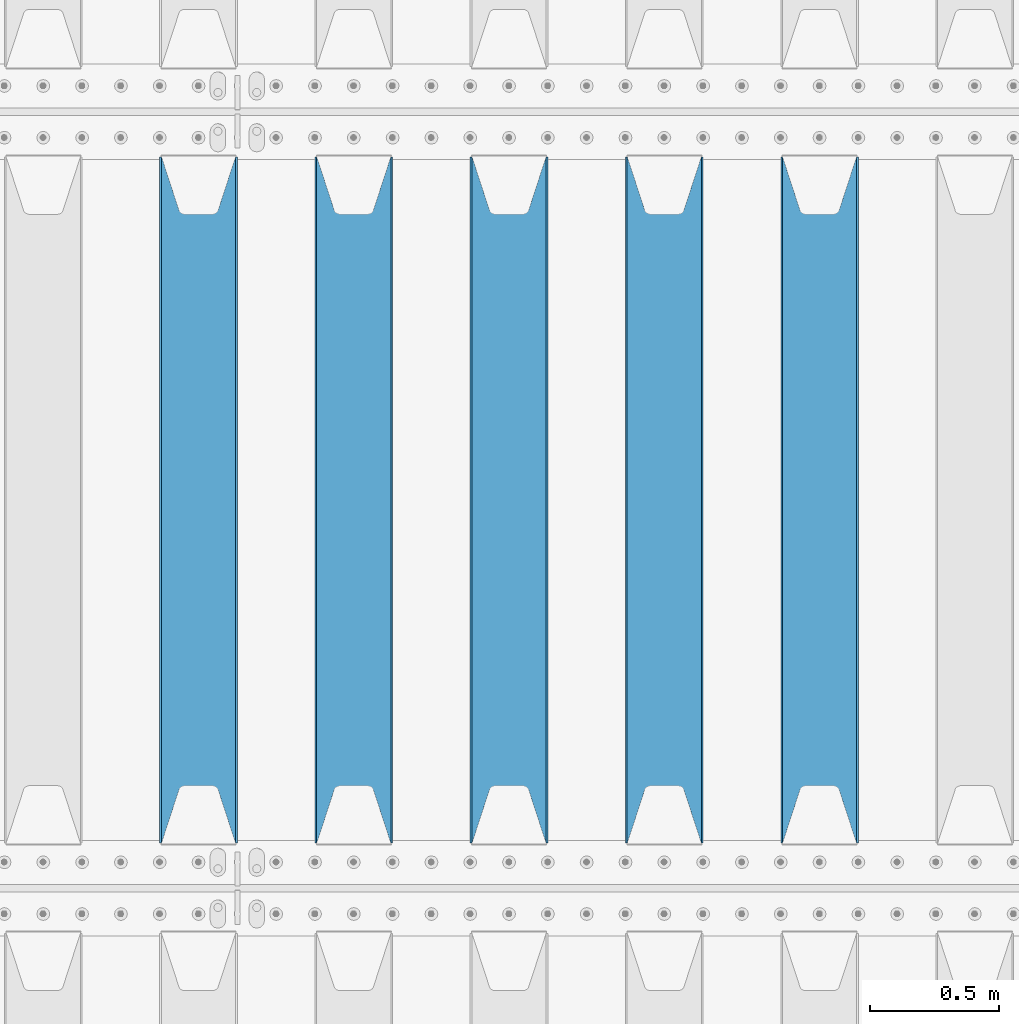
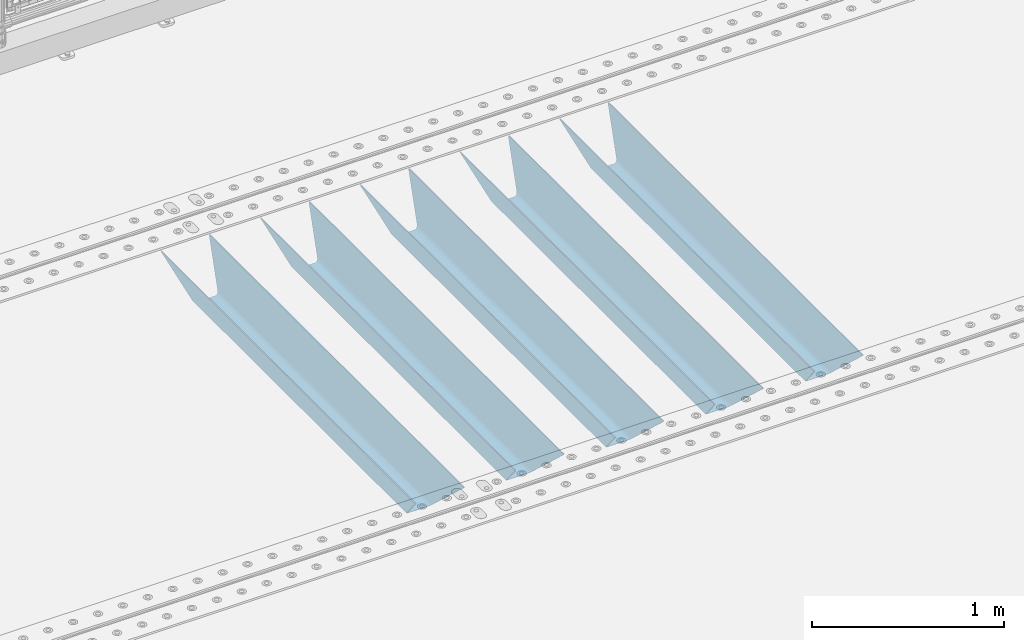
# One storey, part 115 of 240: 5 beams.
"""IFC2X3 building model written with IfcOpenShell, lengths in millimetres."""

from ifc_helpers import new_model, si_unit, frame, origin_with_axes, place, context, subcontext, project, spatial, faceted_brep, material, type_object, element, save


model = new_model("IFC2X3")

# Units and contexts
model_context = context("Model", 3, precision=1e-05, world=origin_with_axes())
body_context = subcontext(model_context, "Body", "Model", "MODEL_VIEW")
ifc_project = project(units=[si_unit("LENGTHUNIT", "METRE", prefix="MILLI"), si_unit("AREAUNIT", "SQUARE_METRE"), si_unit("VOLUMEUNIT", "CUBIC_METRE"), si_unit("MASSUNIT", "GRAM", prefix="KILO"), si_unit("TIMEUNIT", "SECOND"), si_unit("PLANEANGLEUNIT", "RADIAN"), si_unit("SOLIDANGLEUNIT", "STERADIAN"), si_unit("THERMODYNAMICTEMPERATUREUNIT", "DEGREE_CELSIUS"), si_unit("LUMINOUSINTENSITYUNIT", "LUMEN")], contexts=[model_context])

# Site, building, storey
site_placement = place(None, origin_with_axes())
site = spatial("IfcSite", under=ifc_project, at=site_placement, CompositionType="ELEMENT")
building_placement = place(site_placement, origin_with_axes())
building = spatial("IfcBuilding", under=site, at=building_placement, Name="Standard", CompositionType="ELEMENT")
storey_placement = place(building_placement, origin_with_axes())
storey = spatial("IfcBuildingStorey", under=building, at=storey_placement, Name="Undefined", CompositionType="ELEMENT", Elevation=0.0)

# Beams
ifc_material = material(Name="STEEL/S355N")
beam_type = type_object("IfcBeamType", PredefinedType="NOTDEFINED")
beam_1_placement = place(storey_placement, frame((48850.0, 30175.0, -115.0), z_axis=(0.0, 0.0, 1.0), x_axis=(0.0, 1.0, 0.0)))
element("IfcBeam", 1, at=beam_1_placement, inside=storey, type_object=beam_type, material=ifc_material, context=body_context, shape_type="Brep", body=[
    faceted_brep([(0.0, 150.0, 115.0), (0.0, 143.690000000002, 115.0), (2650.00000000297, 143.690000000002, 115.0), (2650.00000000297, 150.0, 115.0), (2650.00000000297, 142.059565218406, 110.000000003094), (2650.00000000297, 148.369565218403, 110.000000003094), (2441.90079219209, -80.1103600731149, -98.0992078077845), (2437.7588105432, -77.5672621345584, -102.241189456673), (2434.06523489747, -74.4080125315522, -105.934765102404), (2430.9108609509, -70.7102721255724, -109.089139048974), (2428.37322971128, -66.5649389910031, -111.626770288588), (2426.51472138055, -62.0739139532889, -113.485278619323), (2425.38102192092, -57.3475956567636, -114.618978078955), (2424.99999999987, -52.5021667386536, -115.0), (2424.99999999987, 52.5021667386536, -115.0), (2425.38102192092, 57.3475956567636, -114.618978078955), (2426.51472138055, 62.0739139532889, -113.485278619323), (2428.37322971128, 66.5649389910031, -111.626770288588), (2430.9108609509, 70.7102721255724, -109.089139048974), (2434.06523489747, 74.4080125315522, -105.934765102404), (2437.7588105432, 77.5672621345584, -102.241189456673), (2441.90079219209, 80.1103600731149, -98.0992078077846), (2446.38936140512, 81.9747917625791, -93.6106385947584), (2448.2494850041, 76.2713538057287, -91.7505149957729), (2444.62967112263, 74.76777986261, -95.3703288772456), (2441.28936334127, 72.7168944282894, -98.710636658607), (2438.31067330439, 70.1691124903809, -101.689326695487), (2435.76682334748, 67.1870637758839, -104.233176652398), (2433.72034654134, 63.8440531834931, -106.279653458539), (2432.22154950042, 60.2222587982324, -107.778450499454), (2431.30727574265, 56.4107117849126, -108.692724257221), (2430.99999999987, 52.5031078186876, -109.0), (2430.99999999987, -52.5031078186876, -109.0), (2431.30727574265, -56.4107117849126, -108.692724257221), (2432.22154950042, -60.2222587982324, -107.778450499454), (2433.72034654134, -63.8440531834931, -106.279653458539), (2435.76682334748, -67.1870637758839, -104.233176652398), (2438.31067330439, -70.1691124903809, -101.689326695487), (2441.28936334127, -72.7168944282894, -98.7106366586071), (2444.62967112263, -74.76777986261, -95.3703288772457), (2448.2494850041, -76.2713538057287, -91.7505149957729), (2650.00000000297, -142.059565218406, 110.000000003094), (2650.00000000297, -148.369565218403, 110.000000003094), (2446.38936140512, -81.9747917625791, -93.6106385947584), (2650.00000000297, -143.690000000002, 115.0), (2650.00000000297, -150.0, 115.0), (0.0, -143.690000000002, 115.0), (0.0, -150.0, 115.0), (0.0, -148.369565218258, 110.000000002667), (203.610638597427, -81.9747917625791, -93.6106385947584), (208.09920781045, -80.1103600731149, -98.0992078077845), (212.241189459342, -77.5672621345584, -102.241189456673), (215.93476510507, -74.4080125315522, -105.934765102404), (219.089139051641, -70.7102721255724, -109.089139048974), (221.626770291256, -66.5649389910031, -111.626770288588), (223.485278621989, -62.0739139532889, -113.485278619323), (224.618978081624, -57.3475956567636, -114.618978078955), (225.000000002663, -52.5021667386536, -115.0), (225.000000002663, 52.5021667386536, -115.0), (224.618978081624, 57.3475956567636, -114.618978078955), (223.485278621989, 62.0739139532889, -113.485278619323), (221.626770291256, 66.5649389910031, -111.626770288588), (219.089139051641, 70.7102721255724, -109.089139048974), (215.93476510507, 74.4080125315522, -105.934765102404), (212.241189459342, 77.5672621345584, -102.241189456673), (208.09920781045, 80.1103600731149, -98.0992078077846), (203.610638597427, 81.9747917625791, -93.6106385947584), (0.0, 148.369565218258, 110.000000002667), (0.0, 142.05956521826, 110.000000002667), (201.750514998439, 76.2713538057287, -91.7505149957729), (205.370328879908, 74.76777986261, -95.3703288772456), (208.710636661275, 72.7168944282894, -98.710636658607), (211.689326698153, 70.1691124903809, -101.689326695487), (214.233176655063, 67.1870637758839, -104.233176652398), (216.279653461206, 63.8440531834931, -106.279653458539), (217.778450502123, 60.2222587982324, -107.778450499454), (218.692724259887, 56.4107117849126, -108.692724257221), (219.000000002667, 52.5031078186876, -109.0), (219.000000002667, -52.5031078186876, -109.0), (218.692724259887, -56.4107117849126, -108.692724257221), (217.778450502123, -60.2222587982324, -107.778450499454), (216.279653461206, -63.8440531834931, -106.279653458539), (214.233176655063, -67.1870637758839, -104.233176652398), (211.689326698153, -70.1691124903809, -101.689326695487), (208.710636661275, -72.7168944282894, -98.7106366586071), (205.370328879915, -74.76777986261, -95.3703288772457), (201.750514998439, -76.2713538057287, -91.7505149957729), (0.0, -142.05956521826, 110.000000002667)], [[[0, 1, 2, 3]], [[3, 2, 4, 5]], [[6, 7, 8, 9, 10, 11, 12, 13, 14, 15, 16, 17, 18, 19, 20, 21, 22, 5, 4, 23, 24, 25, 26, 27, 28, 29, 30, 31, 32, 33, 34, 35, 36, 37, 38, 39, 40, 41, 42, 43]], [[44, 45, 42, 41]], [[46, 47, 45, 44]], [[43, 42, 45, 47, 48, 49]], [[6, 43, 49, 50]], [[7, 6, 50, 51]], [[8, 7, 51, 52]], [[9, 8, 52, 53]], [[10, 9, 53, 54]], [[11, 10, 54, 55]], [[12, 11, 55, 56]], [[13, 12, 56, 57]], [[14, 13, 57, 58]], [[15, 14, 58, 59]], [[16, 15, 59, 60]], [[17, 16, 60, 61]], [[18, 17, 61, 62]], [[19, 18, 62, 63]], [[20, 19, 63, 64]], [[21, 20, 64, 65]], [[22, 21, 65, 66]], [[0, 3, 5, 22, 66, 67]], [[1, 0, 67, 68]], [[23, 4, 2, 1, 68, 69]], [[24, 23, 69, 70]], [[25, 24, 70, 71]], [[26, 25, 71, 72]], [[27, 26, 72, 73]], [[28, 27, 73, 74]], [[29, 28, 74, 75]], [[30, 29, 75, 76]], [[31, 30, 76, 77]], [[32, 31, 77, 78]], [[33, 32, 78, 79]], [[34, 33, 79, 80]], [[35, 34, 80, 81]], [[36, 35, 81, 82]], [[37, 36, 82, 83]], [[38, 37, 83, 84]], [[39, 38, 84, 85]], [[40, 39, 85, 86]], [[46, 44, 41, 40, 86, 87]], [[47, 46, 87, 48]], [[86, 85, 84, 83, 82, 81, 80, 79, 78, 77, 76, 75, 74, 73, 72, 71, 70, 69, 68, 67, 66, 65, 64, 63, 62, 61, 60, 59, 58, 57, 56, 55, 54, 53, 52, 51, 50, 49, 48, 87]]]),
])
beam_2_placement = place(storey_placement, frame((48250.0, 30175.0, -115.0), z_axis=(0.0, 0.0, 1.0), x_axis=(0.0, 1.0, 0.0)))
element("IfcBeam", 2, at=beam_2_placement, inside=storey, type_object=beam_type, material=ifc_material, context=body_context, shape_type="Brep", body=[
    faceted_brep([(0.0, 150.0, 115.0), (0.0, 143.690000000002, 115.0), (2650.00000000297, 143.690000000002, 115.0), (2650.00000000297, 150.0, 115.0), (2650.00000000297, 142.059565218406, 110.000000003094), (2650.00000000297, 148.369565218403, 110.000000003094), (2441.90079219209, -80.1103600731149, -98.0992078077845), (2437.7588105432, -77.5672621345584, -102.241189456673), (2434.06523489747, -74.4080125315522, -105.934765102404), (2430.9108609509, -70.7102721255724, -109.089139048974), (2428.37322971128, -66.5649389910031, -111.626770288588), (2426.51472138055, -62.0739139532889, -113.485278619323), (2425.38102192092, -57.3475956567636, -114.618978078955), (2424.99999999987, -52.5021667386536, -115.0), (2424.99999999987, 52.5021667386536, -115.0), (2425.38102192092, 57.3475956567636, -114.618978078955), (2426.51472138055, 62.0739139532889, -113.485278619323), (2428.37322971128, 66.5649389910031, -111.626770288588), (2430.9108609509, 70.7102721255724, -109.089139048974), (2434.06523489747, 74.4080125315522, -105.934765102404), (2437.7588105432, 77.5672621345584, -102.241189456673), (2441.90079219209, 80.1103600731149, -98.0992078077846), (2446.38936140512, 81.9747917625791, -93.6106385947584), (2448.2494850041, 76.2713538057287, -91.7505149957729), (2444.62967112263, 74.76777986261, -95.3703288772456), (2441.28936334127, 72.7168944282894, -98.710636658607), (2438.31067330439, 70.1691124903809, -101.689326695487), (2435.76682334748, 67.1870637758839, -104.233176652398), (2433.72034654134, 63.8440531834931, -106.279653458539), (2432.22154950042, 60.2222587982324, -107.778450499454), (2431.30727574265, 56.4107117849126, -108.692724257221), (2430.99999999987, 52.5031078186876, -109.0), (2430.99999999987, -52.5031078186876, -109.0), (2431.30727574265, -56.4107117849126, -108.692724257221), (2432.22154950042, -60.2222587982324, -107.778450499454), (2433.72034654134, -63.8440531834931, -106.279653458539), (2435.76682334748, -67.1870637758839, -104.233176652398), (2438.31067330439, -70.1691124903809, -101.689326695487), (2441.28936334127, -72.7168944282894, -98.7106366586071), (2444.62967112263, -74.76777986261, -95.3703288772457), (2448.2494850041, -76.2713538057287, -91.7505149957729), (2650.00000000297, -142.059565218406, 110.000000003094), (2650.00000000297, -148.369565218403, 110.000000003094), (2446.38936140512, -81.9747917625791, -93.6106385947584), (2650.00000000297, -143.690000000002, 115.0), (2650.00000000297, -150.0, 115.0), (0.0, -143.690000000002, 115.0), (0.0, -150.0, 115.0), (0.0, -148.369565218258, 110.000000002667), (203.610638597427, -81.9747917625791, -93.6106385947584), (208.09920781045, -80.1103600731149, -98.0992078077845), (212.241189459342, -77.5672621345584, -102.241189456673), (215.93476510507, -74.4080125315522, -105.934765102404), (219.089139051641, -70.7102721255724, -109.089139048974), (221.626770291256, -66.5649389910031, -111.626770288588), (223.485278621989, -62.0739139532889, -113.485278619323), (224.618978081624, -57.3475956567636, -114.618978078955), (225.000000002663, -52.5021667386536, -115.0), (225.000000002663, 52.5021667386536, -115.0), (224.618978081624, 57.3475956567636, -114.618978078955), (223.485278621989, 62.0739139532889, -113.485278619323), (221.626770291256, 66.5649389910031, -111.626770288588), (219.089139051641, 70.7102721255724, -109.089139048974), (215.93476510507, 74.4080125315522, -105.934765102404), (212.241189459342, 77.5672621345584, -102.241189456673), (208.09920781045, 80.1103600731149, -98.0992078077846), (203.610638597427, 81.9747917625791, -93.6106385947584), (0.0, 148.369565218258, 110.000000002667), (0.0, 142.05956521826, 110.000000002667), (201.750514998439, 76.2713538057287, -91.7505149957729), (205.370328879908, 74.76777986261, -95.3703288772456), (208.710636661275, 72.7168944282894, -98.710636658607), (211.689326698153, 70.1691124903809, -101.689326695487), (214.233176655063, 67.1870637758839, -104.233176652398), (216.279653461206, 63.8440531834931, -106.279653458539), (217.778450502123, 60.2222587982324, -107.778450499454), (218.692724259887, 56.4107117849126, -108.692724257221), (219.000000002667, 52.5031078186876, -109.0), (219.000000002667, -52.5031078186876, -109.0), (218.692724259887, -56.4107117849126, -108.692724257221), (217.778450502123, -60.2222587982324, -107.778450499454), (216.279653461206, -63.8440531834931, -106.279653458539), (214.233176655063, -67.1870637758839, -104.233176652398), (211.689326698153, -70.1691124903809, -101.689326695487), (208.710636661275, -72.7168944282894, -98.7106366586071), (205.370328879915, -74.76777986261, -95.3703288772457), (201.750514998439, -76.2713538057287, -91.7505149957729), (0.0, -142.05956521826, 110.000000002667)], [[[0, 1, 2, 3]], [[3, 2, 4, 5]], [[6, 7, 8, 9, 10, 11, 12, 13, 14, 15, 16, 17, 18, 19, 20, 21, 22, 5, 4, 23, 24, 25, 26, 27, 28, 29, 30, 31, 32, 33, 34, 35, 36, 37, 38, 39, 40, 41, 42, 43]], [[44, 45, 42, 41]], [[46, 47, 45, 44]], [[43, 42, 45, 47, 48, 49]], [[6, 43, 49, 50]], [[7, 6, 50, 51]], [[8, 7, 51, 52]], [[9, 8, 52, 53]], [[10, 9, 53, 54]], [[11, 10, 54, 55]], [[12, 11, 55, 56]], [[13, 12, 56, 57]], [[14, 13, 57, 58]], [[15, 14, 58, 59]], [[16, 15, 59, 60]], [[17, 16, 60, 61]], [[18, 17, 61, 62]], [[19, 18, 62, 63]], [[20, 19, 63, 64]], [[21, 20, 64, 65]], [[22, 21, 65, 66]], [[0, 3, 5, 22, 66, 67]], [[1, 0, 67, 68]], [[23, 4, 2, 1, 68, 69]], [[24, 23, 69, 70]], [[25, 24, 70, 71]], [[26, 25, 71, 72]], [[27, 26, 72, 73]], [[28, 27, 73, 74]], [[29, 28, 74, 75]], [[30, 29, 75, 76]], [[31, 30, 76, 77]], [[32, 31, 77, 78]], [[33, 32, 78, 79]], [[34, 33, 79, 80]], [[35, 34, 80, 81]], [[36, 35, 81, 82]], [[37, 36, 82, 83]], [[38, 37, 83, 84]], [[39, 38, 84, 85]], [[40, 39, 85, 86]], [[46, 44, 41, 40, 86, 87]], [[47, 46, 87, 48]], [[86, 85, 84, 83, 82, 81, 80, 79, 78, 77, 76, 75, 74, 73, 72, 71, 70, 69, 68, 67, 66, 65, 64, 63, 62, 61, 60, 59, 58, 57, 56, 55, 54, 53, 52, 51, 50, 49, 48, 87]]]),
])
beam_3_placement = place(storey_placement, frame((47650.0, 30175.0, -115.0), z_axis=(0.0, 0.0, 1.0), x_axis=(0.0, 1.0, 0.0)))
element("IfcBeam", 3, at=beam_3_placement, inside=storey, type_object=beam_type, material=ifc_material, context=body_context, shape_type="Brep", body=[
    faceted_brep([(0.0, 150.0, 115.0), (0.0, 143.690000000002, 115.0), (2650.00000000297, 143.690000000002, 115.0), (2650.00000000297, 150.0, 115.0), (2650.00000000297, 142.059565218406, 110.000000003094), (2650.00000000297, 148.369565218403, 110.000000003094), (2441.90079219209, -80.1103600731149, -98.0992078077845), (2437.7588105432, -77.5672621345584, -102.241189456673), (2434.06523489747, -74.4080125315522, -105.934765102404), (2430.9108609509, -70.7102721255724, -109.089139048974), (2428.37322971128, -66.5649389910031, -111.626770288588), (2426.51472138055, -62.0739139532889, -113.485278619323), (2425.38102192092, -57.3475956567636, -114.618978078955), (2424.99999999987, -52.5021667386536, -115.0), (2424.99999999987, 52.5021667386536, -115.0), (2425.38102192092, 57.3475956567636, -114.618978078955), (2426.51472138055, 62.0739139532889, -113.485278619323), (2428.37322971128, 66.5649389910031, -111.626770288588), (2430.9108609509, 70.7102721255724, -109.089139048974), (2434.06523489747, 74.4080125315522, -105.934765102404), (2437.7588105432, 77.5672621345584, -102.241189456673), (2441.90079219209, 80.1103600731149, -98.0992078077846), (2446.38936140512, 81.9747917625791, -93.6106385947584), (2448.2494850041, 76.2713538057287, -91.7505149957729), (2444.62967112263, 74.76777986261, -95.3703288772456), (2441.28936334127, 72.7168944282894, -98.710636658607), (2438.31067330439, 70.1691124903809, -101.689326695487), (2435.76682334748, 67.1870637758839, -104.233176652398), (2433.72034654134, 63.8440531834931, -106.279653458539), (2432.22154950042, 60.2222587982324, -107.778450499454), (2431.30727574265, 56.4107117849126, -108.692724257221), (2430.99999999987, 52.5031078186876, -109.0), (2430.99999999987, -52.5031078186876, -109.0), (2431.30727574265, -56.4107117849126, -108.692724257221), (2432.22154950042, -60.2222587982324, -107.778450499454), (2433.72034654134, -63.8440531834931, -106.279653458539), (2435.76682334748, -67.1870637758839, -104.233176652398), (2438.31067330439, -70.1691124903809, -101.689326695487), (2441.28936334127, -72.7168944282894, -98.7106366586071), (2444.62967112263, -74.76777986261, -95.3703288772457), (2448.2494850041, -76.2713538057287, -91.7505149957729), (2650.00000000297, -142.059565218406, 110.000000003094), (2650.00000000297, -148.369565218403, 110.000000003094), (2446.38936140512, -81.9747917625791, -93.6106385947584), (2650.00000000297, -143.690000000002, 115.0), (2650.00000000297, -150.0, 115.0), (0.0, -143.690000000002, 115.0), (0.0, -150.0, 115.0), (0.0, -148.369565218258, 110.000000002667), (203.610638597427, -81.9747917625791, -93.6106385947584), (208.09920781045, -80.1103600731149, -98.0992078077845), (212.241189459342, -77.5672621345584, -102.241189456673), (215.93476510507, -74.4080125315522, -105.934765102404), (219.089139051641, -70.7102721255724, -109.089139048974), (221.626770291256, -66.5649389910031, -111.626770288588), (223.485278621989, -62.0739139532889, -113.485278619323), (224.618978081624, -57.3475956567636, -114.618978078955), (225.000000002663, -52.5021667386536, -115.0), (225.000000002663, 52.5021667386536, -115.0), (224.618978081624, 57.3475956567636, -114.618978078955), (223.485278621989, 62.0739139532889, -113.485278619323), (221.626770291256, 66.5649389910031, -111.626770288588), (219.089139051641, 70.7102721255724, -109.089139048974), (215.93476510507, 74.4080125315522, -105.934765102404), (212.241189459342, 77.5672621345584, -102.241189456673), (208.09920781045, 80.1103600731149, -98.0992078077846), (203.610638597427, 81.9747917625791, -93.6106385947584), (0.0, 148.369565218258, 110.000000002667), (0.0, 142.05956521826, 110.000000002667), (201.750514998439, 76.2713538057287, -91.7505149957729), (205.370328879908, 74.76777986261, -95.3703288772456), (208.710636661275, 72.7168944282894, -98.710636658607), (211.689326698153, 70.1691124903809, -101.689326695487), (214.233176655063, 67.1870637758839, -104.233176652398), (216.279653461206, 63.8440531834931, -106.279653458539), (217.778450502123, 60.2222587982324, -107.778450499454), (218.692724259887, 56.4107117849126, -108.692724257221), (219.000000002667, 52.5031078186876, -109.0), (219.000000002667, -52.5031078186876, -109.0), (218.692724259887, -56.4107117849126, -108.692724257221), (217.778450502123, -60.2222587982324, -107.778450499454), (216.279653461206, -63.8440531834931, -106.279653458539), (214.233176655063, -67.1870637758839, -104.233176652398), (211.689326698153, -70.1691124903809, -101.689326695487), (208.710636661275, -72.7168944282894, -98.7106366586071), (205.370328879915, -74.76777986261, -95.3703288772457), (201.750514998439, -76.2713538057287, -91.7505149957729), (0.0, -142.05956521826, 110.000000002667)], [[[0, 1, 2, 3]], [[3, 2, 4, 5]], [[6, 7, 8, 9, 10, 11, 12, 13, 14, 15, 16, 17, 18, 19, 20, 21, 22, 5, 4, 23, 24, 25, 26, 27, 28, 29, 30, 31, 32, 33, 34, 35, 36, 37, 38, 39, 40, 41, 42, 43]], [[44, 45, 42, 41]], [[46, 47, 45, 44]], [[43, 42, 45, 47, 48, 49]], [[6, 43, 49, 50]], [[7, 6, 50, 51]], [[8, 7, 51, 52]], [[9, 8, 52, 53]], [[10, 9, 53, 54]], [[11, 10, 54, 55]], [[12, 11, 55, 56]], [[13, 12, 56, 57]], [[14, 13, 57, 58]], [[15, 14, 58, 59]], [[16, 15, 59, 60]], [[17, 16, 60, 61]], [[18, 17, 61, 62]], [[19, 18, 62, 63]], [[20, 19, 63, 64]], [[21, 20, 64, 65]], [[22, 21, 65, 66]], [[0, 3, 5, 22, 66, 67]], [[1, 0, 67, 68]], [[23, 4, 2, 1, 68, 69]], [[24, 23, 69, 70]], [[25, 24, 70, 71]], [[26, 25, 71, 72]], [[27, 26, 72, 73]], [[28, 27, 73, 74]], [[29, 28, 74, 75]], [[30, 29, 75, 76]], [[31, 30, 76, 77]], [[32, 31, 77, 78]], [[33, 32, 78, 79]], [[34, 33, 79, 80]], [[35, 34, 80, 81]], [[36, 35, 81, 82]], [[37, 36, 82, 83]], [[38, 37, 83, 84]], [[39, 38, 84, 85]], [[40, 39, 85, 86]], [[46, 44, 41, 40, 86, 87]], [[47, 46, 87, 48]], [[86, 85, 84, 83, 82, 81, 80, 79, 78, 77, 76, 75, 74, 73, 72, 71, 70, 69, 68, 67, 66, 65, 64, 63, 62, 61, 60, 59, 58, 57, 56, 55, 54, 53, 52, 51, 50, 49, 48, 87]]]),
])
beam_4_placement = place(storey_placement, frame((47050.0, 30175.0, -115.0), z_axis=(0.0, 0.0, 1.0), x_axis=(0.0, 1.0, 0.0)))
element("IfcBeam", 4, at=beam_4_placement, inside=storey, type_object=beam_type, material=ifc_material, context=body_context, shape_type="Brep", body=[
    faceted_brep([(0.0, 150.0, 115.0), (0.0, 143.690000000002, 115.0), (2650.00000000297, 143.690000000002, 115.0), (2650.00000000297, 150.0, 115.0), (2650.00000000297, 142.059565218406, 110.000000003094), (2650.00000000297, 148.369565218403, 110.000000003094), (2441.90079219209, -80.1103600731149, -98.0992078077845), (2437.7588105432, -77.5672621345584, -102.241189456673), (2434.06523489747, -74.4080125315522, -105.934765102404), (2430.9108609509, -70.7102721255724, -109.089139048974), (2428.37322971128, -66.5649389910031, -111.626770288588), (2426.51472138055, -62.0739139532889, -113.485278619323), (2425.38102192092, -57.3475956567636, -114.618978078955), (2424.99999999987, -52.5021667386536, -115.0), (2424.99999999987, 52.5021667386536, -115.0), (2425.38102192092, 57.3475956567636, -114.618978078955), (2426.51472138055, 62.0739139532889, -113.485278619323), (2428.37322971128, 66.5649389910031, -111.626770288588), (2430.9108609509, 70.7102721255724, -109.089139048974), (2434.06523489747, 74.4080125315522, -105.934765102404), (2437.7588105432, 77.5672621345584, -102.241189456673), (2441.90079219209, 80.1103600731149, -98.0992078077846), (2446.38936140512, 81.9747917625791, -93.6106385947584), (2448.2494850041, 76.2713538057287, -91.7505149957729), (2444.62967112263, 74.76777986261, -95.3703288772456), (2441.28936334127, 72.7168944282894, -98.710636658607), (2438.31067330439, 70.1691124903809, -101.689326695487), (2435.76682334748, 67.1870637758839, -104.233176652398), (2433.72034654134, 63.8440531834931, -106.279653458539), (2432.22154950042, 60.2222587982324, -107.778450499454), (2431.30727574265, 56.4107117849126, -108.692724257221), (2430.99999999987, 52.5031078186876, -109.0), (2430.99999999987, -52.5031078186876, -109.0), (2431.30727574265, -56.4107117849126, -108.692724257221), (2432.22154950042, -60.2222587982324, -107.778450499454), (2433.72034654134, -63.8440531834931, -106.279653458539), (2435.76682334748, -67.1870637758839, -104.233176652398), (2438.31067330439, -70.1691124903809, -101.689326695487), (2441.28936334127, -72.7168944282894, -98.7106366586071), (2444.62967112263, -74.76777986261, -95.3703288772457), (2448.2494850041, -76.2713538057287, -91.7505149957729), (2650.00000000297, -142.059565218406, 110.000000003094), (2650.00000000297, -148.369565218403, 110.000000003094), (2446.38936140512, -81.9747917625791, -93.6106385947584), (2650.00000000297, -143.690000000002, 115.0), (2650.00000000297, -150.0, 115.0), (0.0, -143.690000000002, 115.0), (0.0, -150.0, 115.0), (0.0, -148.369565218258, 110.000000002667), (203.610638597427, -81.9747917625791, -93.6106385947584), (208.09920781045, -80.1103600731149, -98.0992078077845), (212.241189459342, -77.5672621345584, -102.241189456673), (215.93476510507, -74.4080125315522, -105.934765102404), (219.089139051641, -70.7102721255724, -109.089139048974), (221.626770291256, -66.5649389910031, -111.626770288588), (223.485278621989, -62.0739139532889, -113.485278619323), (224.618978081624, -57.3475956567636, -114.618978078955), (225.000000002663, -52.5021667386536, -115.0), (225.000000002663, 52.5021667386536, -115.0), (224.618978081624, 57.3475956567636, -114.618978078955), (223.485278621989, 62.0739139532889, -113.485278619323), (221.626770291256, 66.5649389910031, -111.626770288588), (219.089139051641, 70.7102721255724, -109.089139048974), (215.93476510507, 74.4080125315522, -105.934765102404), (212.241189459342, 77.5672621345584, -102.241189456673), (208.09920781045, 80.1103600731149, -98.0992078077846), (203.610638597427, 81.9747917625791, -93.6106385947584), (0.0, 148.369565218258, 110.000000002667), (0.0, 142.05956521826, 110.000000002667), (201.750514998439, 76.2713538057287, -91.7505149957729), (205.370328879908, 74.76777986261, -95.3703288772456), (208.710636661275, 72.7168944282894, -98.710636658607), (211.689326698153, 70.1691124903809, -101.689326695487), (214.233176655063, 67.1870637758839, -104.233176652398), (216.279653461206, 63.8440531834931, -106.279653458539), (217.778450502123, 60.2222587982324, -107.778450499454), (218.692724259887, 56.4107117849126, -108.692724257221), (219.000000002667, 52.5031078186876, -109.0), (219.000000002667, -52.5031078186876, -109.0), (218.692724259887, -56.4107117849126, -108.692724257221), (217.778450502123, -60.2222587982324, -107.778450499454), (216.279653461206, -63.8440531834931, -106.279653458539), (214.233176655063, -67.1870637758839, -104.233176652398), (211.689326698153, -70.1691124903809, -101.689326695487), (208.710636661275, -72.7168944282894, -98.7106366586071), (205.370328879915, -74.76777986261, -95.3703288772457), (201.750514998439, -76.2713538057287, -91.7505149957729), (0.0, -142.05956521826, 110.000000002667)], [[[0, 1, 2, 3]], [[3, 2, 4, 5]], [[6, 7, 8, 9, 10, 11, 12, 13, 14, 15, 16, 17, 18, 19, 20, 21, 22, 5, 4, 23, 24, 25, 26, 27, 28, 29, 30, 31, 32, 33, 34, 35, 36, 37, 38, 39, 40, 41, 42, 43]], [[44, 45, 42, 41]], [[46, 47, 45, 44]], [[43, 42, 45, 47, 48, 49]], [[6, 43, 49, 50]], [[7, 6, 50, 51]], [[8, 7, 51, 52]], [[9, 8, 52, 53]], [[10, 9, 53, 54]], [[11, 10, 54, 55]], [[12, 11, 55, 56]], [[13, 12, 56, 57]], [[14, 13, 57, 58]], [[15, 14, 58, 59]], [[16, 15, 59, 60]], [[17, 16, 60, 61]], [[18, 17, 61, 62]], [[19, 18, 62, 63]], [[20, 19, 63, 64]], [[21, 20, 64, 65]], [[22, 21, 65, 66]], [[0, 3, 5, 22, 66, 67]], [[1, 0, 67, 68]], [[23, 4, 2, 1, 68, 69]], [[24, 23, 69, 70]], [[25, 24, 70, 71]], [[26, 25, 71, 72]], [[27, 26, 72, 73]], [[28, 27, 73, 74]], [[29, 28, 74, 75]], [[30, 29, 75, 76]], [[31, 30, 76, 77]], [[32, 31, 77, 78]], [[33, 32, 78, 79]], [[34, 33, 79, 80]], [[35, 34, 80, 81]], [[36, 35, 81, 82]], [[37, 36, 82, 83]], [[38, 37, 83, 84]], [[39, 38, 84, 85]], [[40, 39, 85, 86]], [[46, 44, 41, 40, 86, 87]], [[47, 46, 87, 48]], [[86, 85, 84, 83, 82, 81, 80, 79, 78, 77, 76, 75, 74, 73, 72, 71, 70, 69, 68, 67, 66, 65, 64, 63, 62, 61, 60, 59, 58, 57, 56, 55, 54, 53, 52, 51, 50, 49, 48, 87]]]),
])
beam_5_placement = place(storey_placement, frame((46450.0, 30175.0, -115.0), z_axis=(0.0, 0.0, 1.0), x_axis=(0.0, 1.0, 0.0)))
element("IfcBeam", 5, at=beam_5_placement, inside=storey, type_object=beam_type, material=ifc_material, context=body_context, shape_type="Brep", body=[
    faceted_brep([(0.0, 150.0, 115.0), (0.0, 143.690000000002, 115.0), (2650.00000000297, 143.690000000002, 115.0), (2650.00000000297, 150.0, 115.0), (2650.00000000297, 142.059565218406, 110.000000003094), (2650.00000000297, 148.369565218403, 110.000000003094), (2441.90079219209, -80.1103600731149, -98.0992078077845), (2437.7588105432, -77.5672621345584, -102.241189456673), (2434.06523489747, -74.4080125315522, -105.934765102404), (2430.9108609509, -70.7102721255724, -109.089139048974), (2428.37322971128, -66.5649389910031, -111.626770288588), (2426.51472138055, -62.0739139532889, -113.485278619323), (2425.38102192092, -57.3475956567636, -114.618978078955), (2424.99999999987, -52.5021667386536, -115.0), (2424.99999999987, 52.5021667386536, -115.0), (2425.38102192092, 57.3475956567636, -114.618978078955), (2426.51472138055, 62.0739139532889, -113.485278619323), (2428.37322971128, 66.5649389910031, -111.626770288588), (2430.9108609509, 70.7102721255724, -109.089139048974), (2434.06523489747, 74.4080125315522, -105.934765102404), (2437.7588105432, 77.5672621345584, -102.241189456673), (2441.90079219209, 80.1103600731149, -98.0992078077846), (2446.38936140512, 81.9747917625791, -93.6106385947584), (2448.2494850041, 76.2713538057287, -91.7505149957729), (2444.62967112263, 74.76777986261, -95.3703288772456), (2441.28936334127, 72.7168944282894, -98.710636658607), (2438.31067330439, 70.1691124903809, -101.689326695487), (2435.76682334748, 67.1870637758839, -104.233176652398), (2433.72034654134, 63.8440531834931, -106.279653458539), (2432.22154950042, 60.2222587982324, -107.778450499454), (2431.30727574265, 56.4107117849126, -108.692724257221), (2430.99999999987, 52.5031078186876, -109.0), (2430.99999999987, -52.5031078186876, -109.0), (2431.30727574265, -56.4107117849126, -108.692724257221), (2432.22154950042, -60.2222587982324, -107.778450499454), (2433.72034654134, -63.8440531834931, -106.279653458539), (2435.76682334748, -67.1870637758839, -104.233176652398), (2438.31067330439, -70.1691124903809, -101.689326695487), (2441.28936334127, -72.7168944282894, -98.7106366586071), (2444.62967112263, -74.76777986261, -95.3703288772457), (2448.2494850041, -76.2713538057287, -91.7505149957729), (2650.00000000297, -142.059565218406, 110.000000003094), (2650.00000000297, -148.369565218403, 110.000000003094), (2446.38936140512, -81.9747917625791, -93.6106385947584), (2650.00000000297, -143.690000000002, 115.0), (2650.00000000297, -150.0, 115.0), (0.0, -143.690000000002, 115.0), (0.0, -150.0, 115.0), (0.0, -148.369565218258, 110.000000002667), (203.610638597427, -81.9747917625791, -93.6106385947584), (208.09920781045, -80.1103600731149, -98.0992078077845), (212.241189459342, -77.5672621345584, -102.241189456673), (215.93476510507, -74.4080125315522, -105.934765102404), (219.089139051641, -70.7102721255724, -109.089139048974), (221.626770291256, -66.5649389910031, -111.626770288588), (223.485278621989, -62.0739139532889, -113.485278619323), (224.618978081624, -57.3475956567636, -114.618978078955), (225.000000002663, -52.5021667386536, -115.0), (225.000000002663, 52.5021667386536, -115.0), (224.618978081624, 57.3475956567636, -114.618978078955), (223.485278621989, 62.0739139532889, -113.485278619323), (221.626770291256, 66.5649389910031, -111.626770288588), (219.089139051641, 70.7102721255724, -109.089139048974), (215.93476510507, 74.4080125315522, -105.934765102404), (212.241189459342, 77.5672621345584, -102.241189456673), (208.09920781045, 80.1103600731149, -98.0992078077846), (203.610638597427, 81.9747917625791, -93.6106385947584), (0.0, 148.369565218258, 110.000000002667), (0.0, 142.05956521826, 110.000000002667), (201.750514998439, 76.2713538057287, -91.7505149957729), (205.370328879908, 74.76777986261, -95.3703288772456), (208.710636661275, 72.7168944282894, -98.710636658607), (211.689326698153, 70.1691124903809, -101.689326695487), (214.233176655063, 67.1870637758839, -104.233176652398), (216.279653461206, 63.8440531834931, -106.279653458539), (217.778450502123, 60.2222587982324, -107.778450499454), (218.692724259887, 56.4107117849126, -108.692724257221), (219.000000002667, 52.5031078186876, -109.0), (219.000000002667, -52.5031078186876, -109.0), (218.692724259887, -56.4107117849126, -108.692724257221), (217.778450502123, -60.2222587982324, -107.778450499454), (216.279653461206, -63.8440531834931, -106.279653458539), (214.233176655063, -67.1870637758839, -104.233176652398), (211.689326698153, -70.1691124903809, -101.689326695487), (208.710636661275, -72.7168944282894, -98.7106366586071), (205.370328879915, -74.76777986261, -95.3703288772457), (201.750514998439, -76.2713538057287, -91.7505149957729), (0.0, -142.05956521826, 110.000000002667)], [[[0, 1, 2, 3]], [[3, 2, 4, 5]], [[6, 7, 8, 9, 10, 11, 12, 13, 14, 15, 16, 17, 18, 19, 20, 21, 22, 5, 4, 23, 24, 25, 26, 27, 28, 29, 30, 31, 32, 33, 34, 35, 36, 37, 38, 39, 40, 41, 42, 43]], [[44, 45, 42, 41]], [[46, 47, 45, 44]], [[43, 42, 45, 47, 48, 49]], [[6, 43, 49, 50]], [[7, 6, 50, 51]], [[8, 7, 51, 52]], [[9, 8, 52, 53]], [[10, 9, 53, 54]], [[11, 10, 54, 55]], [[12, 11, 55, 56]], [[13, 12, 56, 57]], [[14, 13, 57, 58]], [[15, 14, 58, 59]], [[16, 15, 59, 60]], [[17, 16, 60, 61]], [[18, 17, 61, 62]], [[19, 18, 62, 63]], [[20, 19, 63, 64]], [[21, 20, 64, 65]], [[22, 21, 65, 66]], [[0, 3, 5, 22, 66, 67]], [[1, 0, 67, 68]], [[23, 4, 2, 1, 68, 69]], [[24, 23, 69, 70]], [[25, 24, 70, 71]], [[26, 25, 71, 72]], [[27, 26, 72, 73]], [[28, 27, 73, 74]], [[29, 28, 74, 75]], [[30, 29, 75, 76]], [[31, 30, 76, 77]], [[32, 31, 77, 78]], [[33, 32, 78, 79]], [[34, 33, 79, 80]], [[35, 34, 80, 81]], [[36, 35, 81, 82]], [[37, 36, 82, 83]], [[38, 37, 83, 84]], [[39, 38, 84, 85]], [[40, 39, 85, 86]], [[46, 44, 41, 40, 86, 87]], [[47, 46, 87, 48]], [[86, 85, 84, 83, 82, 81, 80, 79, 78, 77, 76, 75, 74, 73, 72, 71, 70, 69, 68, 67, 66, 65, 64, 63, 62, 61, 60, 59, 58, 57, 56, 55, 54, 53, 52, 51, 50, 49, 48, 87]]]),
])

save(model, "model.ifc")
